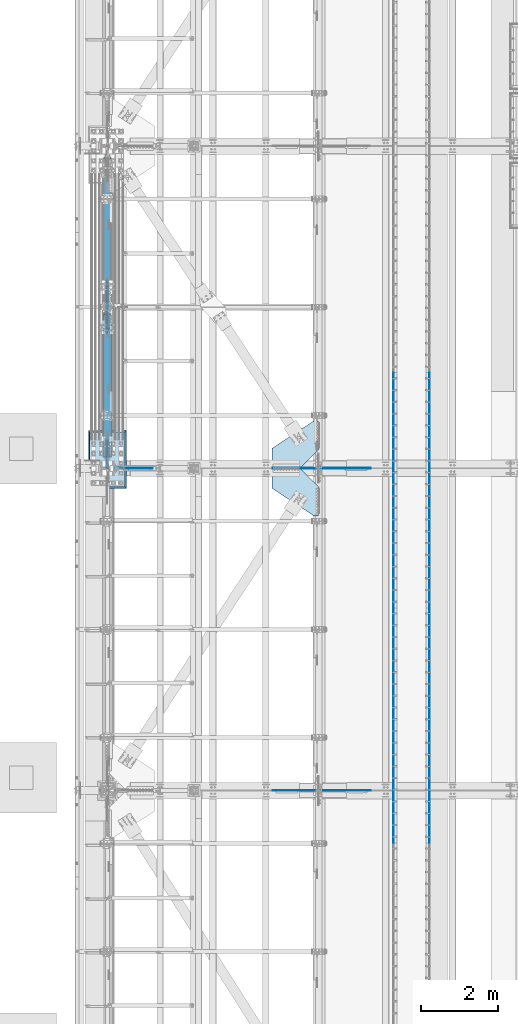
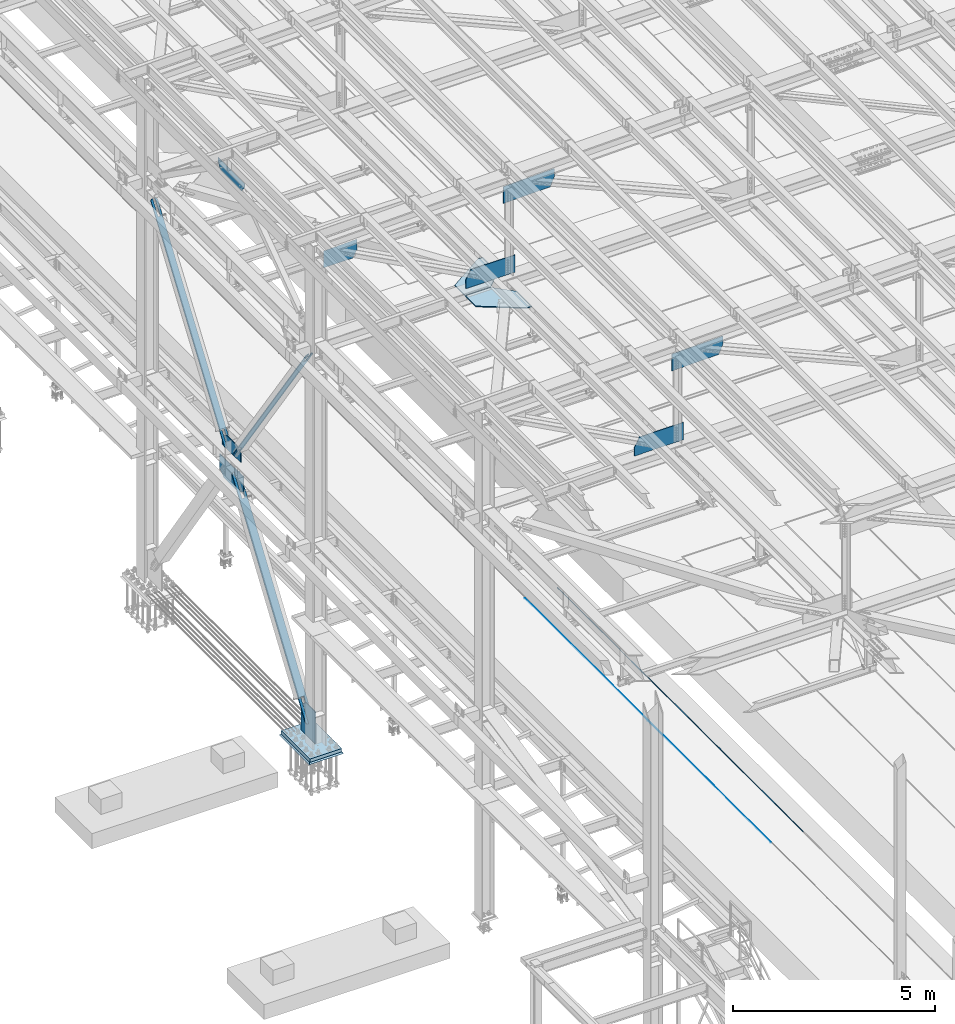
# One storey, part 2977 of 3843: 20 plates, 17 elements without a shape of their own.
"""IFC2X3 building model written with IfcOpenShell, lengths in millimetres."""

from ifc_helpers import new_model, si_unit, frame, origin_with_axes, place, context, subcontext, project, spatial, faceted_brep, material, type_object, element, aggregate, save


model = new_model("IFC2X3")

# Units and contexts
model_context = context("Model", 3, precision=1e-05, world=origin_with_axes())
body_context = subcontext(model_context, "Body", "Model", "MODEL_VIEW")
ifc_project = project(units=[si_unit("LENGTHUNIT", "METRE", prefix="MILLI"), si_unit("AREAUNIT", "SQUARE_METRE"), si_unit("VOLUMEUNIT", "CUBIC_METRE"), si_unit("MASSUNIT", "GRAM", prefix="KILO"), si_unit("TIMEUNIT", "SECOND"), si_unit("PLANEANGLEUNIT", "RADIAN"), si_unit("SOLIDANGLEUNIT", "STERADIAN"), si_unit("THERMODYNAMICTEMPERATUREUNIT", "DEGREE_CELSIUS"), si_unit("LUMINOUSINTENSITYUNIT", "LUMEN")], contexts=[model_context])

# Site, building, storey
site_placement = place(None, origin_with_axes())
site = spatial("IfcSite", under=ifc_project, at=site_placement, CompositionType="ELEMENT")
building_placement = place(site_placement, origin_with_axes())
building = spatial("IfcBuilding", under=site, at=building_placement, Name="Undefined", CompositionType="ELEMENT")
storey_placement = place(building_placement, origin_with_axes())
storey = spatial("IfcBuildingStorey", under=building, at=storey_placement, Name="Undefined", CompositionType="ELEMENT", Elevation=0.0)

# Assembly, plate
assembly_1_placement = place(storey_placement, origin_with_axes())
assembly_1 = element("IfcElementAssembly", 1, at=assembly_1_placement, inside=storey, Name="BEAM", AssemblyPlace="NOTDEFINED", PredefinedType="RIGID_FRAME")
ifc_material_1 = material(Name="STEEL/A572-50")
plate_type_1 = type_object("IfcPlateType", PredefinedType="NOTDEFINED")
plate_1_placement = place(assembly_1_placement, frame((42274.2305128658, 42202.0999999999, 42457.8765315712), z_axis=(-0.00436384400168752, 0.0, 0.999990478387434), x_axis=(-0.999990478387434, 0.0, -0.00436384400169025)))
plate_1 = element("IfcPlate", 2, at=plate_1_placement, type_object=plate_type_1, material=ifc_material_1, Name="PLATE", context=body_context, shape_type="Brep", body=[
    faceted_brep([(0.0, -9.52500000000146, 0.0), (1.10594555735588e-09, -9.52500000000146, 523.235598038023), (1.10594555735588e-09, 9.52500000000146, 523.235598038023), (0.0, 9.52500000000146, 0.0), (1259.35122959658, -9.52500000000146, 528.728641448179), (1259.35122959658, 9.52500000000146, 528.728641448179), (1404.8234222176, -9.52500000000146, 260.883757215037), (1404.8234222176, 9.52500000000146, 260.883757215037), (1404.82342221706, -9.52500000000146, -2.96859070658684e-09), (1404.82342221706, 9.52500000000146, -2.96859070658684e-09)], [[[0, 1, 2, 3]], [[1, 4, 5, 2]], [[4, 6, 7, 5]], [[6, 8, 9, 7]], [[8, 0, 3, 9]], [[5, 7, 9, 3, 2]], [[8, 6, 4, 1, 0]]]),
])
aggregate(assembly_1, [plate_1])

assembly_2_placement = place(storey_placement, origin_with_axes())
assembly_2 = element("IfcElementAssembly", 3, at=assembly_2_placement, inside=storey, Name="BEAM", AssemblyPlace="NOTDEFINED", PredefinedType="RIGID_FRAME")
plate_2_placement = place(assembly_2_placement, frame((42274.6288727742, 50558.6999999999, 42462.430738261), z_axis=(-0.00512823099762316, 0.0, 0.999986850536963), x_axis=(-0.999986850536963, 0.0, -0.00512823099762594)))
plate_2 = element("IfcPlate", 4, at=plate_2_placement, type_object=plate_type_1, material=ifc_material_1, Name="PLATE", context=body_context, shape_type="Brep", body=[
    faceted_brep([(0.0, -9.52500000000146, 0.0), (1.08411768451333e-09, -9.52500000000146, 522.345951998475), (1.08411768451333e-09, 9.52500000000146, 522.345951998475), (0.0, 9.52500000000146, 0.0), (1259.54713032951, -9.52500000000146, 528.805680089747), (1259.54713032951, 9.52500000000146, 528.805680089747), (1405.05225276016, -9.52500000000146, 260.978683704641), (1405.05225276016, 9.52500000000146, 260.978683704641), (1405.05225275962, -9.52500000000146, -2.93221091851592e-09), (1405.05225275962, 9.52500000000146, -2.93221091851592e-09)], [[[0, 1, 2, 3]], [[1, 4, 5, 2]], [[4, 6, 7, 5]], [[6, 8, 9, 7]], [[8, 0, 3, 9]], [[5, 7, 9, 3, 2]], [[8, 6, 4, 1, 0]]]),
])
aggregate(assembly_2, [plate_2])

assembly_3_placement = place(storey_placement, origin_with_axes())
assembly_3 = element("IfcElementAssembly", 5, at=assembly_3_placement, inside=storey, Name="EMBED_ANGLE", AssemblyPlace="NOTDEFINED", PredefinedType="RIGID_FRAME")
ifc_material_2 = material(Name="STEEL/A36")
plate_type_2 = type_object("IfcPlateType", PredefinedType="NOTDEFINED")
plate_3_placement = place(assembly_3_placement, frame((44925.9959999999, 46942.3749999999, 30479.9999977113), z_axis=(0.0, -1.0, 0.0), x_axis=(0.0, 0.0, -1.0)))
plate_3 = element("IfcPlate", 6, at=plate_3_placement, type_object=plate_type_2, material=ifc_material_2, Name="PLATE", context=body_context, shape_type="Brep", body=[
    faceted_brep([(15.875, 1.58750000000146, 6096.0), (15.875, 1.58749999204883, -3.63797880709171e-12), (11.1125018504281, 6.35000000000582, -7.27595761418343e-12), (11.1124996186481, 6.34999999999854, 6096.0), (0.0, -6.3499999046162, 0.0), (3.81471181754023e-07, -6.34999999999854, 6096.0), (3.81471181754023e-07, 6.34999999999854, 6096.0), (7.27595761418343e-12, 6.3499999046162, 0.0), (15.875, -6.35000000000582, 3.63797880709171e-12), (15.875, -6.34999999999854, 6096.0)], [[[0, 1, 2, 3]], [[4, 5, 6, 7]], [[8, 9, 5, 4]], [[6, 5, 9, 0, 3]], [[7, 6, 3, 2]], [[8, 4, 7, 2, 1]], [[9, 8, 1, 0]]]),
])
aggregate(assembly_3, [plate_3])

assembly_4_placement = place(storey_placement, origin_with_axes())
assembly_4 = element("IfcElementAssembly", 7, at=assembly_4_placement, inside=storey, Name="EMBED_ANGLE", AssemblyPlace="NOTDEFINED", PredefinedType="RIGID_FRAME")
plate_4_placement = place(assembly_4_placement, frame((44925.9959999999, 53038.3749999999, 30479.9999980927), z_axis=(0.0, -1.0, 0.0), x_axis=(0.0, 0.0, -1.0)))
plate_4 = element("IfcPlate", 8, at=plate_4_placement, type_object=plate_type_2, material=ifc_material_2, Name="PLATE", context=body_context, shape_type="Brep", body=[
    faceted_brep([(15.875, 1.58750000000146, 6096.0), (15.875, 1.58749999204883, -3.63797880709171e-12), (11.1125018504281, 6.35000000000582, -7.27595761418343e-12), (11.1124996186481, 6.34999999999854, 6096.0), (0.0, -6.3499999046162, 0.0), (3.81471181754023e-07, -6.34999999999854, 6096.0), (3.81471181754023e-07, 6.34999999999854, 6096.0), (7.27595761418343e-12, 6.3499999046162, 0.0), (15.875, -6.35000000000582, 3.63797880709171e-12), (15.875, -6.34999999999854, 6096.0)], [[[0, 1, 2, 3]], [[4, 5, 6, 7]], [[8, 9, 5, 4]], [[6, 5, 9, 0, 3]], [[7, 6, 3, 2]], [[8, 4, 7, 2, 1]], [[9, 8, 1, 0]]]),
])
aggregate(assembly_4, [plate_4])

assembly_5_placement = place(storey_placement, origin_with_axes())
assembly_5 = element("IfcElementAssembly", 9, at=assembly_5_placement, inside=storey, Name="EMBED_ANGLE", AssemblyPlace="NOTDEFINED", PredefinedType="RIGID_FRAME")
plate_5_placement = place(assembly_5_placement, frame((43998.896, 46942.3749999999, 30479.9999980926), z_axis=(0.0, -1.0, 0.0), x_axis=(0.0, 0.0, -1.0)))
plate_5 = element("IfcPlate", 10, at=plate_5_placement, type_object=plate_type_2, material=ifc_material_2, Name="PLATE", context=body_context, shape_type="Brep", body=[
    faceted_brep([(15.8749946755343, -1.58750000000146, 6096.0), (11.1124999999702, -6.34999999999854, 6096.0), (11.1125001907349, -6.35000000006371, 0.0), (15.875, -1.58750000024156, -3.63797880709171e-12), (0.0, -6.3499999046162, 0.0), (3.81471181754023e-07, -6.34999999999854, 6096.0), (3.81471181754023e-07, 6.34999999999854, 6096.0), (7.27595761418343e-12, 6.3499999046162, 0.0), (15.875, 6.34999999999854, 6096.0), (15.875, 6.34999999999854, -3.63797880709171e-12)], [[[0, 1, 2, 3]], [[4, 5, 6, 7]], [[8, 9, 7, 6]], [[9, 8, 0, 3]], [[4, 7, 9, 3, 2]], [[5, 4, 2, 1]], [[8, 6, 5, 1, 0]]]),
])
aggregate(assembly_5, [plate_5])

assembly_6_placement = place(storey_placement, origin_with_axes())
assembly_6 = element("IfcElementAssembly", 11, at=assembly_6_placement, inside=storey, Name="EMBED_ANGLE", AssemblyPlace="NOTDEFINED", PredefinedType="RIGID_FRAME")
plate_6_placement = place(assembly_6_placement, frame((43998.896, 53038.3749999999, 30479.9999984741), z_axis=(0.0, -1.0, 0.0), x_axis=(0.0, 0.0, -1.0)))
plate_6 = element("IfcPlate", 12, at=plate_6_placement, type_object=plate_type_2, material=ifc_material_2, Name="PLATE", context=body_context, shape_type="Brep", body=[
    faceted_brep([(15.8749946755343, -1.58750000000146, 6096.0), (11.1124999999702, -6.34999999999854, 6096.0), (11.1125001907349, -6.35000000006371, 0.0), (15.875, -1.58750000024156, -3.63797880709171e-12), (0.0, -6.3499999046162, 0.0), (3.81471181754023e-07, -6.34999999999854, 6096.0), (3.81471181754023e-07, 6.34999999999854, 6096.0), (7.27595761418343e-12, 6.3499999046162, 0.0), (15.875, 6.34999999999854, 6096.0), (15.875, 6.34999999999854, -3.63797880709171e-12)], [[[0, 1, 2, 3]], [[4, 5, 6, 7]], [[8, 9, 7, 6]], [[9, 8, 0, 3]], [[4, 7, 9, 3, 2]], [[5, 4, 2, 1]], [[8, 6, 5, 1, 0]]]),
])
aggregate(assembly_6, [plate_6])

assembly_7_placement = place(storey_placement, origin_with_axes())
assembly_7 = element("IfcElementAssembly", 13, at=assembly_7_placement, inside=storey, Name="CB", AssemblyPlace="NOTDEFINED", PredefinedType="RIGID_FRAME")
plate_type_3 = type_object("IfcPlateType", PredefinedType="NOTDEFINED")
plate_7_placement = place(assembly_7_placement, frame((36672.8375, 54914.527474505, 36506.2328239714), z_axis=(0.0, 0.572746499261054, 0.819732546373637), x_axis=(-1.0, 0.0, 0.0)))
plate_7 = element("IfcPlate", 14, at=plate_7_placement, type_object=plate_type_3, material=ifc_material_2, Name="CB", context=body_context, shape_type="Brep", body=[
    faceted_brep([(0.0, -12.7000000001135, 65.0875015259007), (0.0, -12.7000000182597, 6401.59609690412), (0.0, 12.6999999816398, 6401.59609690415), (0.0, 12.6999999999025, 65.0875015259462), (4.95449104381987, -12.7000000183325, 6426.50400539227), (4.95449104381987, 12.6999999815671, 6426.50400539229), (19.0636878264413, -12.700000018398, 6447.61991060384), (19.0636878264413, 12.6999999815016, 6447.61991060387), (40.1795930378867, -12.7000000184344, 6461.72910738653), (40.1795930378867, 12.6999999814725, 6461.72910738658), (65.0875000000015, -12.7000000184344, 6466.68359843041), (65.0875000000015, 12.6999999814579, 6466.68359843042), (65.0875000000015, -12.7000000024382, 5992.41679934617), (65.0875000000015, 12.6999999976542, 5992.41679934617), (128.587500000001, -12.7000000024382, 5992.41679934617), (128.587500000001, 12.6999999976542, 5992.41679934617), (128.587498474124, -12.7000000184344, 6466.68359843041), (128.587498474124, 12.6999999814579, 6466.68359843042), (153.495406962116, -12.7000000184344, 6461.72910738653), (153.495406962116, 12.6999999814725, 6461.72910738658), (174.611312173562, -12.700000018398, 6447.61991060384), (174.611312173562, 12.6999999815016, 6447.61991060387), (188.720508956183, -12.7000000183325, 6426.50400539227), (188.720508956183, 12.6999999815671, 6426.50400539229), (193.675000000003, -12.7000000182597, 6401.59609690412), (193.675000000003, 12.6999999816398, 6401.59609690415), (193.674999999988, -12.7000000001135, 65.0875015259007), (193.674999999988, 12.6999999999025, 65.0875015259462), (188.720508956161, -12.7000000000698, 40.1795930378939), (188.720508956161, 12.6999999999389, 40.1795930379376), (174.611312173554, -12.7000000000407, 19.0636878264304), (174.611312173554, 12.6999999999753, 19.0636878264741), (153.495406962102, -12.7000000000189, 4.9544910438035), (153.495406962102, 12.7000000000044, 4.95449104384716), (128.587499999994, -12.7000000000044, -2.00088834390044e-11), (128.587499999994, 12.7000000000116, 1.81898940354586e-11), (128.587500000001, -12.7000000002372, 474.266799203462), (128.587500000001, 12.6999999998588, 474.266799203477), (65.0875000000015, -12.7000000002372, 474.266799203462), (65.0875000000015, 12.6999999998588, 474.266799203477), (65.0875015258789, -12.7000000000044, -2.00088834390044e-11), (65.0875015258789, 12.7000000000116, 1.81898940354586e-11), (40.1795930378867, -12.7000000000189, 4.9544910438035), (40.1795930378867, 12.7000000000044, 4.95449104384716), (19.063687826434, -12.7000000000407, 19.0636878264304), (19.063687826434, 12.6999999999753, 19.0636878264741), (4.95449104382715, -12.7000000000698, 40.1795930378939), (4.95449104382715, 12.6999999999389, 40.1795930379376)], [[[0, 1, 2, 3]], [[1, 4, 5, 2]], [[4, 6, 7, 5]], [[6, 8, 9, 7]], [[8, 10, 11, 9]], [[10, 12, 13, 11]], [[12, 14, 15, 13]], [[14, 16, 17, 15]], [[16, 18, 19, 17]], [[18, 20, 21, 19]], [[20, 22, 23, 21]], [[22, 24, 25, 23]], [[24, 26, 27, 25]], [[26, 28, 29, 27]], [[28, 30, 31, 29]], [[30, 32, 33, 31]], [[32, 34, 35, 33]], [[34, 36, 37, 35]], [[36, 38, 39, 37]], [[38, 40, 41, 39]], [[40, 42, 43, 41]], [[42, 44, 45, 43]], [[44, 46, 47, 45]], [[46, 0, 3, 47]], [[5, 7, 9, 11, 13, 15, 17, 19, 21, 23, 25, 27, 29, 31, 33, 35, 37, 39, 41, 43, 45, 47, 3, 2]], [[46, 44, 42, 40, 38, 36, 34, 32, 30, 28, 26, 24, 22, 20, 18, 16, 14, 12, 10, 8, 6, 4, 1, 0]]]),
])
aggregate(assembly_7, [plate_7])

assembly_8_placement = place(storey_placement, origin_with_axes())
assembly_8 = element("IfcElementAssembly", 15, at=assembly_8_placement, inside=storey, Name="CB", AssemblyPlace="NOTDEFINED", PredefinedType="RIGID_FRAME")
plate_8_placement = place(assembly_8_placement, frame((36479.1625, 54559.472525495, 36506.2328239714), z_axis=(0.0, -0.572746499261054, 0.819732546373637), x_axis=(1.0, 0.0, 0.0)))
plate_8 = element("IfcPlate", 16, at=plate_8_placement, type_object=plate_type_3, material=ifc_material_2, Name="CB", context=body_context, shape_type="Brep", body=[
    faceted_brep([(0.0, -12.7000000001135, 65.0875015259007), (0.0, -12.7000000182597, 6401.59609690412), (0.0, 12.6999999816398, 6401.59609690415), (0.0, 12.6999999999025, 65.0875015259462), (4.95449104381987, -12.7000000183325, 6426.50400539227), (4.95449104381987, 12.6999999815671, 6426.50400539229), (19.0636878264413, -12.700000018398, 6447.61991060384), (19.0636878264413, 12.6999999815016, 6447.61991060387), (40.1795930378867, -12.7000000184344, 6461.72910738653), (40.1795930378867, 12.6999999814725, 6461.72910738658), (65.0875000000015, -12.7000000184344, 6466.68359843041), (65.0875000000015, 12.6999999814579, 6466.68359843042), (65.0875000000015, -12.7000000024382, 5992.41679934617), (65.0875000000015, 12.6999999976542, 5992.41679934617), (128.587500000001, -12.7000000024382, 5992.41679934617), (128.587500000001, 12.6999999976542, 5992.41679934617), (128.587498474124, -12.7000000184344, 6466.68359843041), (128.587498474124, 12.6999999814579, 6466.68359843042), (153.495406962116, -12.7000000184344, 6461.72910738653), (153.495406962116, 12.6999999814725, 6461.72910738658), (174.611312173562, -12.700000018398, 6447.61991060384), (174.611312173562, 12.6999999815016, 6447.61991060387), (188.720508956183, -12.7000000183325, 6426.50400539227), (188.720508956183, 12.6999999815671, 6426.50400539229), (193.675000000003, -12.7000000182597, 6401.59609690412), (193.675000000003, 12.6999999816398, 6401.59609690415), (193.674999999988, -12.7000000001135, 65.0875015259007), (193.674999999988, 12.6999999999025, 65.0875015259462), (188.720508956161, -12.7000000000698, 40.1795930378939), (188.720508956161, 12.6999999999389, 40.1795930379376), (174.611312173554, -12.7000000000407, 19.0636878264304), (174.611312173554, 12.6999999999753, 19.0636878264741), (153.495406962102, -12.7000000000189, 4.9544910438035), (153.495406962102, 12.7000000000044, 4.95449104384716), (128.587499999994, -12.7000000000044, -2.00088834390044e-11), (128.587499999994, 12.7000000000116, 1.81898940354586e-11), (128.587500000001, -12.7000000002372, 474.266799203462), (128.587500000001, 12.6999999998588, 474.266799203477), (65.0875000000015, -12.7000000002372, 474.266799203462), (65.0875000000015, 12.6999999998588, 474.266799203477), (65.0875015258789, -12.7000000000044, -2.00088834390044e-11), (65.0875015258789, 12.7000000000116, 1.81898940354586e-11), (40.1795930378867, -12.7000000000189, 4.9544910438035), (40.1795930378867, 12.7000000000044, 4.95449104384716), (19.063687826434, -12.7000000000407, 19.0636878264304), (19.063687826434, 12.6999999999753, 19.0636878264741), (4.95449104382715, -12.7000000000698, 40.1795930378939), (4.95449104382715, 12.6999999999389, 40.1795930379376)], [[[0, 1, 2, 3]], [[1, 4, 5, 2]], [[4, 6, 7, 5]], [[6, 8, 9, 7]], [[8, 10, 11, 9]], [[10, 12, 13, 11]], [[12, 14, 15, 13]], [[14, 16, 17, 15]], [[16, 18, 19, 17]], [[18, 20, 21, 19]], [[20, 22, 23, 21]], [[22, 24, 25, 23]], [[24, 26, 27, 25]], [[26, 28, 29, 27]], [[28, 30, 31, 29]], [[30, 32, 33, 31]], [[32, 34, 35, 33]], [[34, 36, 37, 35]], [[36, 38, 39, 37]], [[38, 40, 41, 39]], [[40, 42, 43, 41]], [[42, 44, 45, 43]], [[44, 46, 47, 45]], [[46, 0, 3, 47]], [[5, 7, 9, 11, 13, 15, 17, 19, 21, 23, 25, 27, 29, 31, 33, 35, 37, 39, 41, 43, 45, 47, 3, 2]], [[46, 44, 42, 40, 38, 36, 34, 32, 30, 28, 26, 24, 22, 20, 18, 16, 14, 12, 10, 8, 6, 4, 1, 0]]]),
])
aggregate(assembly_8, [plate_8])

assembly_9_placement = place(storey_placement, origin_with_axes())
assembly_9 = element("IfcElementAssembly", 17, at=assembly_9_placement, inside=storey, Name="BEAM", AssemblyPlace="NOTDEFINED", PredefinedType="RIGID_FRAME")
plate_type_4 = type_object("IfcPlateType", PredefinedType="NOTDEFINED")
plate_9_placement = place(assembly_9_placement, frame((36576.0, 54278.5593264909, 36436.3), z_axis=(0.0, 1.0, 0.0), x_axis=(0.0, 0.0, 1.0)))
plate_9 = element("IfcPlate", 18, at=plate_9_placement, type_object=plate_type_4, material=ifc_material_1, Name="CB", context=body_context, shape_type="Brep", body=[
    faceted_brep([(0.0, -12.6999999999971, 0.0), (0.0, -12.6999999999971, 916.881347018192), (0.0, 12.6999999999971, 916.881347018192), (0.0, 12.6999999999971, 0.0), (258.56111329596, -12.6999999999971, 916.881347018192), (258.56111329596, 12.6999999999971, 916.881347018192), (398.583313588024, -12.6999999999971, 716.477232663303), (398.583313588024, 12.6999999999971, 716.477232663303), (398.583313588024, -12.6999999999971, 464.790673509095), (398.583313588024, 12.6999999999971, 464.790673509095), (398.583313588024, -12.6999999999971, 200.404114354889), (398.583313588024, 12.6999999999971, 200.404114354889), (258.56111329596, -12.6999999999971, 0.0), (258.56111329596, 12.6999999999971, 0.0)], [[[0, 1, 2, 3]], [[1, 4, 5, 2]], [[4, 6, 7, 5]], [[6, 8, 9, 7]], [[8, 10, 11, 9]], [[10, 12, 13, 11]], [[12, 0, 3, 13]], [[5, 7, 9, 11, 13, 3, 2]], [[12, 10, 8, 6, 4, 1, 0]]]),
])

assembly_10_placement = place(storey_placement, origin_with_axes())
assembly_10 = element("IfcElementAssembly", 19, at=assembly_10_placement, inside=storey, Name="BEAM", AssemblyPlace="NOTDEFINED", PredefinedType="RIGID_FRAME")
plate_type_5 = type_object("IfcPlateType", PredefinedType="NOTDEFINED")
plate_10_placement = place(assembly_10_placement, frame((36788.7249999825, 50558.7, 45030.0478635281), z_axis=(1.0, 0.0, 0.0), x_axis=(0.0, 0.0, -1.0)))
plate_10 = element("IfcPlate", 20, at=plate_10_placement, type_object=plate_type_5, material=ifc_material_1, Name="PLATE", context=body_context, shape_type="Brep", body=[
    faceted_brep([(22.2331557193393, 9.52499999999418, 0.0), (3.17609494728822, -9.52499999999418, 0.0), (-22.6800638260756, -9.52500000000146, 949.470300186826), (-3.63712432188186, 9.52500000000146, 949.988880915589), (292.772656777583, -9.52500000000146, 958.060764999558), (292.772656777583, 9.52500000000146, 958.060764999558), (516.580743169732, -9.52500000000146, 837.952726114876), (516.580743169732, 9.52500000000146, 837.952726114876), (516.580743169732, -9.52500000000146, 0.0), (516.580743169732, 9.52500000000146, 0.0)], [[[0, 1, 2, 3]], [[4, 5, 3, 2]], [[4, 6, 7, 5]], [[6, 8, 9, 7]], [[9, 8, 1, 0]], [[5, 7, 9, 0, 3]], [[8, 6, 4, 2, 1]]]),
])

assembly_11_placement = place(storey_placement, origin_with_axes())
assembly_11 = element("IfcElementAssembly", 21, at=assembly_11_placement, inside=storey, Name="PLATE", AssemblyPlace="NOTDEFINED", PredefinedType="RIGID_FRAME")
plate_type_6 = type_object("IfcPlateType", PredefinedType="NOTDEFINED")
plate_11_placement = place(assembly_11_placement, frame((41579.8, 50565.843748021, 42232.2630004883), z_axis=(0.0, 1.0, 0.0), x_axis=(-1.0, 0.0, 0.0)))
plate_11 = element("IfcPlate", 22, at=plate_11_placement, type_object=plate_type_6, material=ifc_material_1, Name="PLATE", context=body_context, shape_type="Brep", body=[
    faceted_brep([(0.0, -14.2874999999985, 0.0), (-477.837500000001, -14.2874999999985, 475.456249999988), (-477.837500000001, 14.2874999999985, 475.456249999988), (0.0, 14.2874999999985, 0.0), (-477.837500000001, -14.2874999999985, 1212.05624999999), (-477.837500000001, 14.2874999999985, 1212.05624999999), (-330.200000000099, -14.2874999999985, 1212.05624999636), (-330.200000000099, 14.2874999999985, 1212.05624999636), (730.249999999854, -14.2874999999985, 515.833758773311), (730.249999999854, 14.2874999999985, 515.833758773311), (730.249999999854, -14.2874999999985, 2.91038304567337e-11), (730.249999999854, 14.2874999999985, 2.91038304567337e-11)], [[[0, 1, 2, 3]], [[1, 4, 5, 2]], [[4, 6, 7, 5]], [[6, 8, 9, 7]], [[8, 10, 11, 9]], [[10, 0, 3, 11]], [[5, 7, 9, 11, 3, 2]], [[10, 8, 6, 4, 1, 0]]]),
])
aggregate(assembly_11, [plate_11])

assembly_12_placement = place(storey_placement, origin_with_axes())
assembly_12 = element("IfcElementAssembly", 23, at=assembly_12_placement, inside=storey, Name="PLATE", AssemblyPlace="NOTDEFINED", PredefinedType="RIGID_FRAME")
plate_12_placement = place(assembly_12_placement, frame((41579.8, 50551.556248021, 42232.2630004883), z_axis=(0.0, -1.0, 0.0), x_axis=(-1.0, 0.0, 0.0)))
plate_12 = element("IfcPlate", 24, at=plate_12_placement, type_object=plate_type_6, material=ifc_material_1, Name="PLATE", context=body_context, shape_type="Brep", body=[
    faceted_brep([(0.0, -14.2874999999985, 0.0), (-477.837500000001, -14.2874999999985, 475.456249999988), (-477.837500000001, 14.2874999999985, 475.456249999988), (0.0, 14.2874999999985, 0.0), (-477.837500000001, -14.2874999999985, 1212.05624999999), (-477.837500000001, 14.2874999999985, 1212.05624999999), (-330.200000000099, -14.2874999999985, 1212.05624999636), (-330.200000000099, 14.2874999999985, 1212.05624999636), (730.249999999854, -14.2874999999985, 515.833758773311), (730.249999999854, 14.2874999999985, 515.833758773311), (730.249999999854, -14.2874999999985, 2.91038304567337e-11), (730.249999999854, 14.2874999999985, 2.91038304567337e-11)], [[[0, 1, 2, 3]], [[1, 4, 5, 2]], [[4, 6, 7, 5]], [[6, 8, 9, 7]], [[8, 10, 11, 9]], [[10, 0, 3, 11]], [[5, 7, 9, 11, 3, 2]], [[10, 8, 6, 4, 1, 0]]]),
])
aggregate(assembly_12, [plate_12])

# Plate
plate_type_7 = type_object("IfcPlateType", PredefinedType="NOTDEFINED")
plate_13_placement = place(assembly_10_placement, frame((43395.2620320891, 50558.7, 45205.7852686464), z_axis=(0.0262151189924408, 0.0, -0.999656324711754), x_axis=(-0.999656324711754, 0.0, -0.026215118992442)))
plate_13 = element("IfcPlate", 25, at=plate_13_placement, type_object=plate_type_7, material=ifc_material_1, Name="PLATE", context=body_context, shape_type="Brep", body=[
    faceted_brep([(0.0, -9.52500000000146, 0.0), (7.93079379945993e-10, -9.52500000000146, 234.430248811543), (7.93079379945993e-10, 9.52500000000146, 234.430248811543), (0.0, 9.52500000000146, 0.0), (130.335901861465, -9.52500000000146, 509.958092707668), (130.335901861465, 9.52500000000146, 509.958092707668), (1473.73728364486, -9.52500000000146, 509.958092703142), (1473.73728364486, 9.52500000000146, 509.958092703142), (1460.36393387706, -9.52500000000146, -4.93309926241636e-09), (1460.36393387706, 9.52500000000146, -4.93309926241636e-09)], [[[0, 1, 2, 3]], [[1, 4, 5, 2]], [[4, 6, 7, 5]], [[6, 8, 9, 7]], [[8, 0, 3, 9]], [[5, 7, 9, 3, 2]], [[8, 6, 4, 1, 0]]]),
])

aggregate(assembly_10, [plate_10, plate_13])

# Assembly, plate
assembly_13_placement = place(storey_placement, origin_with_axes())
assembly_13 = element("IfcElementAssembly", 26, at=assembly_13_placement, inside=storey, Name="COLUMN", AssemblyPlace="NOTDEFINED", PredefinedType="RIGID_FRAME")
plate_type_8 = type_object("IfcPlateType", PredefinedType="NOTDEFINED")
plate_14_placement = place(assembly_13_placement, frame((36576.0, 50571.4, 30162.5), z_axis=(0.0, 0.0, 1.0), x_axis=(0.0, 1.0, 0.0)))
plate_14 = element("IfcPlate", 27, at=plate_14_placement, type_object=plate_type_8, material=ifc_material_1, Name="CB", context=body_context, shape_type="Brep", body=[
    faceted_brep([(0.0, -12.6999999999971, 19.0499992370605), (0.0, -12.6999999999971, 942.254570209607), (0.0, 12.6999999999971, 942.254570209607), (0.0, 12.6999999999971, 19.0499992370605), (19.0499992370605, -12.6999999999971, 961.304569446667), (19.0499992370605, 12.6999999999971, 961.304569446667), (477.459274804351, -12.6999999999971, 961.304569446667), (477.459274804351, 12.6999999999971, 961.304569446667), (707.843688003049, -12.6999999999971, 803.230592603264), (707.843688003049, 12.6999999999971, 803.230592603264), (707.843688003049, -12.6999999999971, 0.0), (707.843688003049, 12.6999999999971, 0.0), (19.0500015258731, -12.6999999999971, -6.33008312433958e-10), (19.0500015258731, 12.6999999999971, 0.0)], [[[0, 1, 2, 3]], [[1, 4, 5, 2]], [[4, 6, 7, 5]], [[6, 8, 9, 7]], [[8, 10, 11, 9]], [[10, 12, 13, 11]], [[12, 0, 3, 13]], [[5, 7, 9, 11, 13, 3, 2]], [[12, 10, 8, 6, 4, 1, 0]]]),
])

# Plate
plate_type_9 = type_object("IfcPlateType", PredefinedType="NOTDEFINED")
plate_15_placement = place(assembly_9_placement, frame((36576.0, 54142.079592498, 35632.0086563323), z_axis=(0.0, 1.0, 0.0), x_axis=(0.0, 0.0, 1.0)))
plate_15 = element("IfcPlate", 28, at=plate_15_placement, type_object=plate_type_9, material=ifc_material_1, Name="CB", context=body_context, shape_type="Brep", body=[
    faceted_brep([(0.0, -12.6999999999971, 0.0), (-158.073978181652, -12.6999999999971, 230.384415149136), (-158.073978181652, 12.6999999999971, 230.384415149136), (0.0, 12.6999999999971, 0.0), (-158.073978181652, -12.6999999999971, 601.270406193056), (-158.073978181652, 12.6999999999971, 601.270406193056), (-158.073978181652, -12.6999999999971, 959.456399904215), (-158.073978181652, 12.6999999999971, 959.456399904215), (-1.33824505610391e-06, -12.6999999999971, 1189.84081310291), (-1.33824505610391e-06, 12.6999999999971, 1189.84081310291), (435.991343667716, -12.6999999999971, 1189.84081310291), (435.991343667716, 12.6999999999971, 1189.84081310291), (435.991343667716, 12.6999999999971, 0.0), (435.991343667716, -12.6999999999971, 0.0)], [[[0, 1, 2, 3]], [[1, 4, 5, 2]], [[4, 6, 7, 5]], [[6, 8, 9, 7]], [[9, 8, 10, 11]], [[3, 2, 5, 7, 9, 11, 12]], [[0, 3, 12, 13]], [[8, 6, 4, 1, 0, 13, 10]], [[12, 11, 10, 13]]]),
])

aggregate(assembly_9, [plate_9, plate_15])

# Assembly, plate
assembly_14_placement = place(storey_placement, origin_with_axes())
assembly_14 = element("IfcElementAssembly", 29, at=assembly_14_placement, inside=storey, Name="CB", AssemblyPlace="NOTDEFINED", PredefinedType="RIGID_FRAME")
plate_type_10 = type_object("IfcPlateType", PredefinedType="NOTDEFINED")
plate_16_placement = place(assembly_14_placement, frame((36690.3, 50860.8952672955, 30602.9335281061), z_axis=(0.0, 0.5657622650086, 0.824568408012542), x_axis=(-1.0, 0.0, 0.0)))
plate_16 = element("IfcPlate", 30, at=plate_16_placement, type_object=plate_type_10, material=ifc_material_2, Name="CB", context=body_context, shape_type="Brep", body=[
    faceted_brep([(0.0, -15.8749999996799, 73.0250015258098), (0.0, -15.8749999668507, 6465.9984944254), (0.0, 15.8750000332511, 6465.99849442527), (0.0, 15.875000000422, 73.0250015256788), (5.55869725451339, -15.8749999667052, 6493.94395265774), (5.55869725451339, 15.8750000333966, 6493.94395265761), (21.3885277507725, -15.8749999665888, 6517.63496820041), (21.3885277507725, 15.8750000335131, 6517.63496820028), (45.0795432934901, -15.874999966516, 6533.46479869664), (45.0795432934901, 15.8750000335858, 6533.46479869651), (73.0250000000015, -15.8749999664869, 6539.02349595114), (73.0250000000015, 15.8750000336149, 6539.02349595101), (73.0250000000015, -15.8750000049622, 5844.43674799455), (73.0250000000015, 15.8749999949505, 5844.43674799455), (155.575000000004, -15.8750000049622, 5844.43674799455), (155.575000000004, 15.8749999949505, 5844.43674799455), (155.574998474127, -15.8749999664869, 6539.02349595114), (155.574998474127, 15.8750000336149, 6539.02349595101), (183.520456706516, -15.874999966516, 6533.46479869664), (183.520456706516, 15.8750000335858, 6533.46479869651), (207.211472249233, -15.8749999665888, 6517.63496820041), (207.211472249233, 15.8750000335131, 6517.63496820028), (223.041302745492, -15.8749999667052, 6493.94395265774), (223.041302745492, 15.8750000333966, 6493.94395265761), (228.600000000006, -15.8749999668507, 6465.9984944254), (228.600000000006, 15.8750000332511, 6465.99849442527), (228.600000000006, -15.8749999996799, 73.0250015258098), (228.600000000006, 15.875000000422, 73.0250015256788), (223.041302745492, -15.8749999998254, 45.0795432934756), (223.041302745492, 15.8750000002765, 45.0795432933373), (207.211472249233, -15.8749999999563, 21.3885277508089), (207.211472249233, 15.8750000001455, 21.3885277506743), (183.520456706516, -15.8750000000291, 5.55869725457887), (183.520456706516, 15.8750000000728, 5.55869725444427), (155.575000000004, -15.8750000000437, 6.54836185276508e-11), (155.574999999975, 15.875, 0.0), (155.575000000004, -15.8750000005384, 694.586748007643), (155.575000000004, 15.8749999993743, 694.586748007639), (73.0250000000015, -15.8750000005384, 694.586748007643), (73.0250000000015, 15.8749999993743, 694.586748007639), (73.0250015258789, -15.8750000000437, 6.54836185276508e-11), (73.0250015258789, 15.8750000000437, -6.18456397205591e-11), (45.0795432934901, -15.8750000000291, 5.55869725457887), (45.0795432934901, 15.8750000000728, 5.55869725444427), (21.3885277507725, -15.8749999999563, 21.3885277508089), (21.3885277507725, 15.8750000001455, 21.3885277506743), (5.55869725451339, -15.8749999998254, 45.0795432934756), (5.55869725451339, 15.8750000002765, 45.0795432933373)], [[[0, 1, 2, 3]], [[1, 4, 5, 2]], [[4, 6, 7, 5]], [[6, 8, 9, 7]], [[8, 10, 11, 9]], [[10, 12, 13, 11]], [[12, 14, 15, 13]], [[14, 16, 17, 15]], [[16, 18, 19, 17]], [[18, 20, 21, 19]], [[20, 22, 23, 21]], [[22, 24, 25, 23]], [[24, 26, 27, 25]], [[26, 28, 29, 27]], [[28, 30, 31, 29]], [[30, 32, 33, 31]], [[32, 34, 35, 33]], [[34, 36, 37, 35]], [[36, 38, 39, 37]], [[38, 40, 41, 39]], [[40, 42, 43, 41]], [[42, 44, 45, 43]], [[44, 46, 47, 45]], [[46, 0, 3, 47]], [[5, 7, 9, 11, 13, 15, 17, 19, 21, 23, 25, 27, 29, 31, 33, 35, 37, 39, 41, 43, 45, 47, 3, 2]], [[46, 44, 42, 40, 38, 36, 34, 32, 30, 28, 26, 24, 22, 20, 18, 16, 14, 12, 10, 8, 6, 4, 1, 0]]]),
])
aggregate(assembly_14, [plate_16])

assembly_15_placement = place(storey_placement, origin_with_axes())
assembly_15 = element("IfcElementAssembly", 31, at=assembly_15_placement, inside=storey, Name="BEAM", AssemblyPlace="NOTDEFINED", PredefinedType="RIGID_FRAME")
plate_type_11 = type_object("IfcPlateType", PredefinedType="NOTDEFINED")
plate_17_placement = place(assembly_15_placement, frame((43397.1446502164, 42202.1, 45200.3821023981), z_axis=(0.0254539099934773, 0.0, -0.999675996743967), x_axis=(-0.999675996743967, 0.0, -0.0254539099934786)))
plate_17 = element("IfcPlate", 32, at=plate_17_placement, type_object=plate_type_11, material=ifc_material_1, Name="PLATE", context=body_context, shape_type="Brep", body=[
    faceted_brep([(0.0, -9.52500000000146, 0.0), (4.80213202536106e-10, -9.52500000000146, 235.059954750293), (4.80213202536106e-10, 9.52500000000146, 235.059954750293), (0.0, 9.52500000000146, 0.0), (130.28732670343, -9.52500000000146, 510.610773045781), (130.28732670343, 9.52500000000146, 510.610773045781), (1475.21966734595, -9.52500000000146, 510.610773042987), (1475.21966734595, 9.52500000000146, 510.610773042987), (1462.21841394334, -9.52500000000146, -3.04862624034286e-09), (1462.21841394334, 9.52500000000146, -3.04862624034286e-09)], [[[0, 1, 2, 3]], [[1, 4, 5, 2]], [[4, 6, 7, 5]], [[6, 8, 9, 7]], [[8, 0, 3, 9]], [[5, 7, 9, 3, 2]], [[8, 6, 4, 1, 0]]]),
])
aggregate(assembly_15, [plate_17])

assembly_16_placement = place(storey_placement, origin_with_axes())
assembly_16 = element("IfcElementAssembly", 33, at=assembly_16_placement, inside=storey, Name="BEAM", AssemblyPlace="NOTDEFINED", PredefinedType="RIGID_FRAME")
plate_type_12 = type_object("IfcPlateType", PredefinedType="NOTDEFINED")
plate_18_placement = place(assembly_16_placement, frame((36563.3000000002, 55398.9786718983, 45002.4500000022), z_axis=(0.0, 0.0, -1.0), x_axis=(0.0, -1.0, 0.0)))
plate_18 = element("IfcPlate", 34, at=plate_18_placement, type_object=plate_type_12, material=ifc_material_1, context=body_context, shape_type="Brep", body=[
    faceted_brep([(0.0, -6.3499999046162, 0.0), (0.0, -6.34999999999854, 107.914709618752), (0.0, 6.34999999999854, 107.914709618752), (7.27595761418343e-12, 6.3499999046162, 0.0), (147.42628116945, -6.34999999999854, 314.75158162311), (147.42628116945, 6.34999999999854, 314.75158162311), (1176.5310664634, -6.34999999999854, 314.75158162311), (1176.5310664634, 6.34999999999854, 314.75158162311), (1323.95734763292, -6.34999999999854, 107.914709617915), (1323.95734763292, 6.34999999999854, 107.914709617915), (1323.95734763292, -6.34999999999854, 0.0), (1323.95734763292, 6.34999999999854, 0.0)], [[[0, 1, 2, 3]], [[1, 4, 5, 2]], [[4, 6, 7, 5]], [[6, 8, 9, 7]], [[8, 10, 11, 9]], [[10, 0, 3, 11]], [[5, 7, 9, 11, 3, 2]], [[10, 8, 6, 4, 1, 0]]]),
])
aggregate(assembly_16, [plate_18])

assembly_17_placement = place(storey_placement, origin_with_axes())
assembly_17 = element("IfcElementAssembly", 35, at=assembly_17_placement, inside=storey, Name="GROUT", AssemblyPlace="NOTDEFINED", PredefinedType="REINFORCEMENT_UNIT")
ifc_material_3 = material(Name="CONCRETE/Concrete_Undefined")
plate_type_13 = type_object("IfcPlateType", PredefinedType="NOTDEFINED")
plate_19_placement = place(assembly_17_placement, frame((36080.7, 50038.0, 30041.85), z_axis=(0.0, 1.0, 0.0), x_axis=(1.0, 0.0, 0.0)))
plate_19 = element("IfcPlate", 36, at=plate_19_placement, type_object=plate_type_13, material=ifc_material_3, Name="GROUT", context=body_context, shape_type="Brep", body=[
    faceted_brep([(38.0999999997948, -19.0499999997955, 1460.49999999932), (0.0, 19.0499999999993, 1498.59997558594), (0.0, 19.0500000000029, 0.0), (38.1000000006916, -19.0499999999811, 38.1000000006607), (952.500000000204, -19.0499999998101, 38.1000000006607), (990.599975585938, 19.0499999999993, 0.0), (990.599975585938, 19.0499999999993, 1498.59997558594), (952.500000000204, -19.0499999999956, 1460.49999999932)], [[[0, 1, 2, 3]], [[4, 5, 6, 7]], [[4, 7, 0, 3]], [[5, 4, 3, 2]], [[6, 5, 2, 1]], [[7, 6, 1, 0]]]),
])
aggregate(assembly_17, [plate_19])

# Plate
plate_type_14 = type_object("IfcPlateType", PredefinedType="NOTDEFINED")
plate_20_placement = place(assembly_13_placement, frame((36118.8, 50076.1, 30111.7), z_axis=(0.0, 1.0, 0.0), x_axis=(1.0, 0.0, 0.0)))
plate_20 = element("IfcPlate", 37, at=plate_20_placement, type_object=plate_type_14, material=ifc_material_1, Name="PLATE", context=body_context, shape_type="Brep", body=[
    faceted_brep([(0.0, -50.7999999999993, 0.0), (0.0, -50.7999999999993, 1422.40002441406), (0.0, 50.7999999999993, 1422.40002441406), (0.0, 50.7999999999993, 0.0), (914.400024414062, -50.7999999999993, 1422.40002441406), (914.400024414062, 50.7999999999993, 1422.40002441406), (914.400024414062, -50.7999999999993, 0.0), (914.400024414062, 50.7999999999993, 0.0)], [[[0, 1, 2, 3]], [[1, 4, 5, 2]], [[4, 6, 7, 5]], [[6, 0, 3, 7]], [[5, 7, 3, 2]], [[6, 4, 1, 0]]]),
])

aggregate(assembly_13, [plate_14, plate_20])

save(model, "model.ifc")
